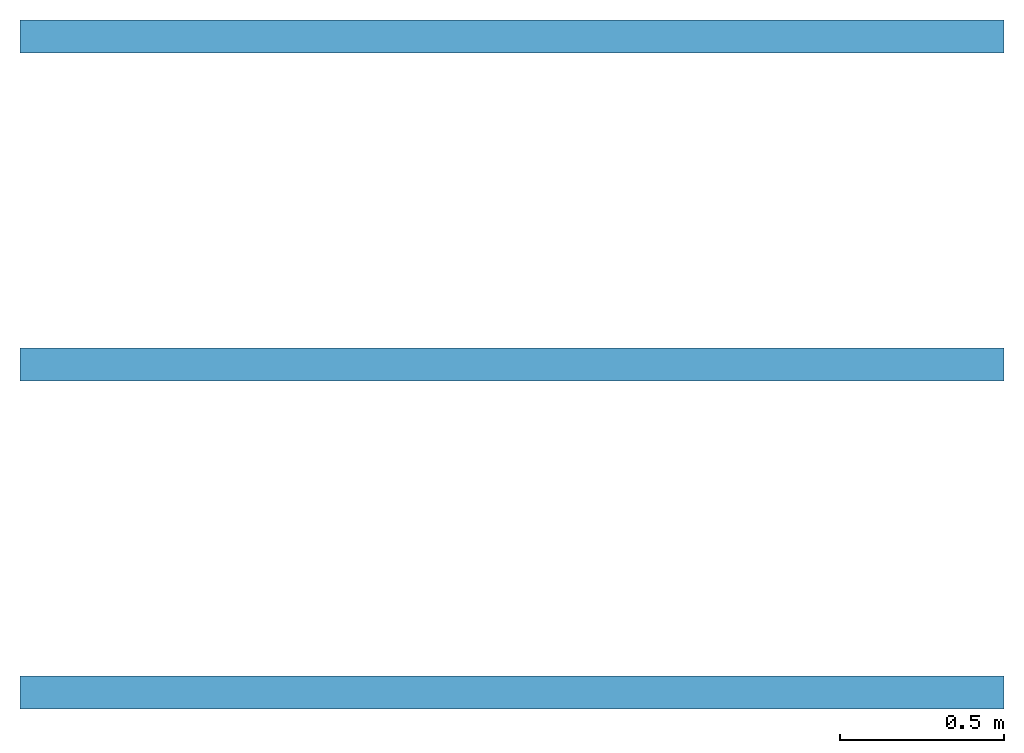
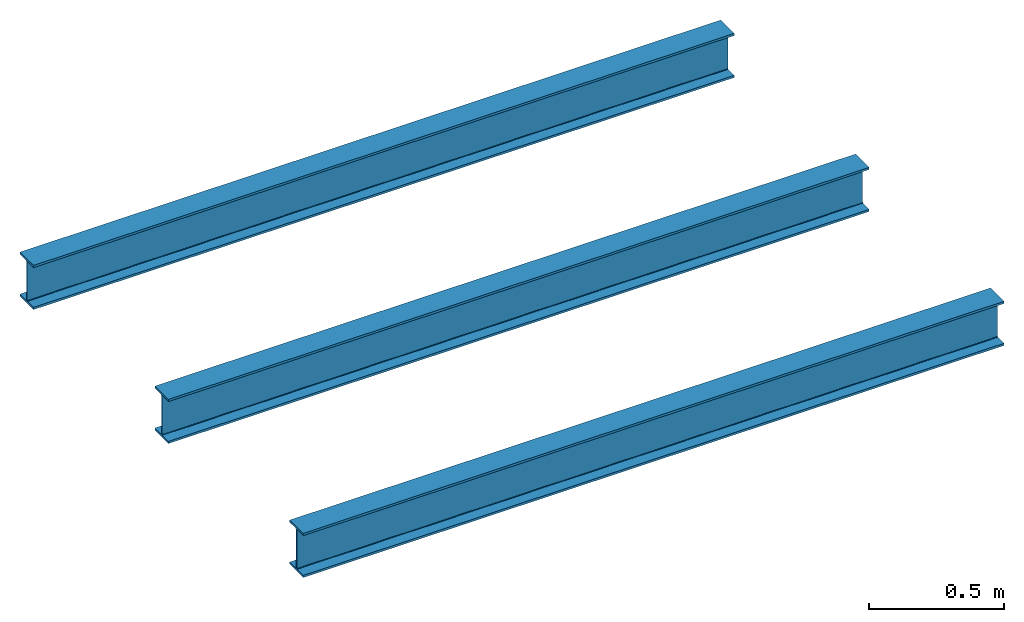
# One storey: 3 beams, 1 element without a shape of its own.
"""IFC4 building model written with IfcOpenShell, lengths in metres."""

from ifc_helpers import new_model, entity, si_unit, converted_unit, frame, origin_with_axes, origin_2d_with_axis, place, context, subcontext, project, spatial, i_section, extrude, material, material_profile, profile_set, profile_usage, type_object, element, aggregate, save


model = new_model("IFC4")

# Units and contexts
model_context = context("Model", 3, precision=1e-05, world=origin_with_axes())
plan_context = context("Plan", 2, precision=1e-05, world=origin_2d_with_axis())
body_context = subcontext(model_context, "Body", "Model", "MODEL_VIEW")
ifc_project = project(units=[si_unit("LENGTHUNIT", "METRE"), converted_unit("PLANEANGLEUNIT", "degree", entity("IfcReal", 0.0174532925199433), si_unit("PLANEANGLEUNIT", "RADIAN"), dimensions=[0, 0, 0, 0, 0, 0, 0]), si_unit("AREAUNIT", "SQUARE_METRE"), si_unit("VOLUMEUNIT", "CUBIC_METRE")], contexts=[model_context, plan_context])

# Site, building, storey
site_placement = place(None, origin_with_axes())
site = spatial("IfcSite", under=ifc_project, at=site_placement)
building_placement = place(site_placement, origin_with_axes())
building = spatial("IfcBuilding", under=site, at=building_placement, Name="Building")
storey_placement = place(building_placement, frame((21.6933784484863, 32.0777740478516, -13.822114944458), z_axis=(0.0, 0.0, 1.0), x_axis=(1.0, 0.0, 0.0)))
storey = spatial("IfcBuildingStorey", under=building, at=storey_placement, Name="Storey")

# Assembly, beams
assembly_placement = place(storey_placement, frame((-21.6933784484863, -32.0777740478516, 13.822114944458), z_axis=(0.0, 0.0, 1.0), x_axis=(1.0, 0.0, 0.0)))
assembly = element("IfcElementAssembly", 1, at=assembly_placement, inside=storey, Name="Assembly")
ifc_material = material()
ifc_material_profile = material_profile(ifc_material, i_section(OverallWidth=0.1, OverallDepth=0.2, WebThickness=0.005, FlangeThickness=0.01, FilletRadius=0.005))
ifc_profile_set = profile_set([ifc_material_profile])
ifc_profile_usage_1 = profile_usage(ifc_profile_set, cardinal=5)
beam_type = type_object("IfcBeamType", Name="B1", PredefinedType="NOTDEFINED", material=ifc_profile_set)
beam_1_placement = place(assembly_placement, frame((0.0, 0.0, 0.0), z_axis=(0.999999999999994, -7.54979012640429e-08, 7.54979012640429e-08), x_axis=(7.54979012640431e-08, 0.999999999999997, 7.16093850883224e-15)))
beam_1 = element("IfcBeam", 2, at=beam_1_placement, type_object=beam_type, material=ifc_profile_usage_1, Name="Beam", context=body_context, shape_type="SweptSolid", body=[
    extrude(i_section(OverallWidth=0.1, OverallDepth=0.2, WebThickness=0.005, FlangeThickness=0.01, FilletRadius=0.005), origin_with_axes(), (0.0, 0.0, 1.0), 3.0),
])
ifc_profile_usage_2 = profile_usage(ifc_profile_set, cardinal=5)
beam_2_placement = place(assembly_placement, frame((0.0, 2.0, 0.0), z_axis=(0.999999999999994, -7.54979012640429e-08, 7.54979012640429e-08), x_axis=(7.54979012640431e-08, 0.999999999999997, 7.16093850883224e-15)))
beam_2 = element("IfcBeam", 3, at=beam_2_placement, type_object=beam_type, material=ifc_profile_usage_2, Name="Beam", context=body_context, shape_type="SweptSolid", body=[
    extrude(i_section(OverallWidth=0.1, OverallDepth=0.2, WebThickness=0.005, FlangeThickness=0.01, FilletRadius=0.005), origin_with_axes(), (0.0, 0.0, 1.0), 3.0),
])
ifc_profile_usage_3 = profile_usage(ifc_profile_set, cardinal=5)
beam_3_placement = place(assembly_placement, frame((0.0, 1.0, 0.0), z_axis=(0.999999999999994, -7.54979012640429e-08, 7.54979012640429e-08), x_axis=(7.54979012640431e-08, 0.999999999999997, 7.16093850883224e-15)))
beam_3 = element("IfcBeam", 4, at=beam_3_placement, type_object=beam_type, material=ifc_profile_usage_3, Name="Beam", context=body_context, shape_type="SweptSolid", body=[
    extrude(i_section(OverallWidth=0.1, OverallDepth=0.2, WebThickness=0.005, FlangeThickness=0.01, FilletRadius=0.005), origin_with_axes(), (0.0, 0.0, 1.0), 3.0),
])
aggregate(assembly, [beam_1, beam_2, beam_3])

save(model, "model.ifc")
